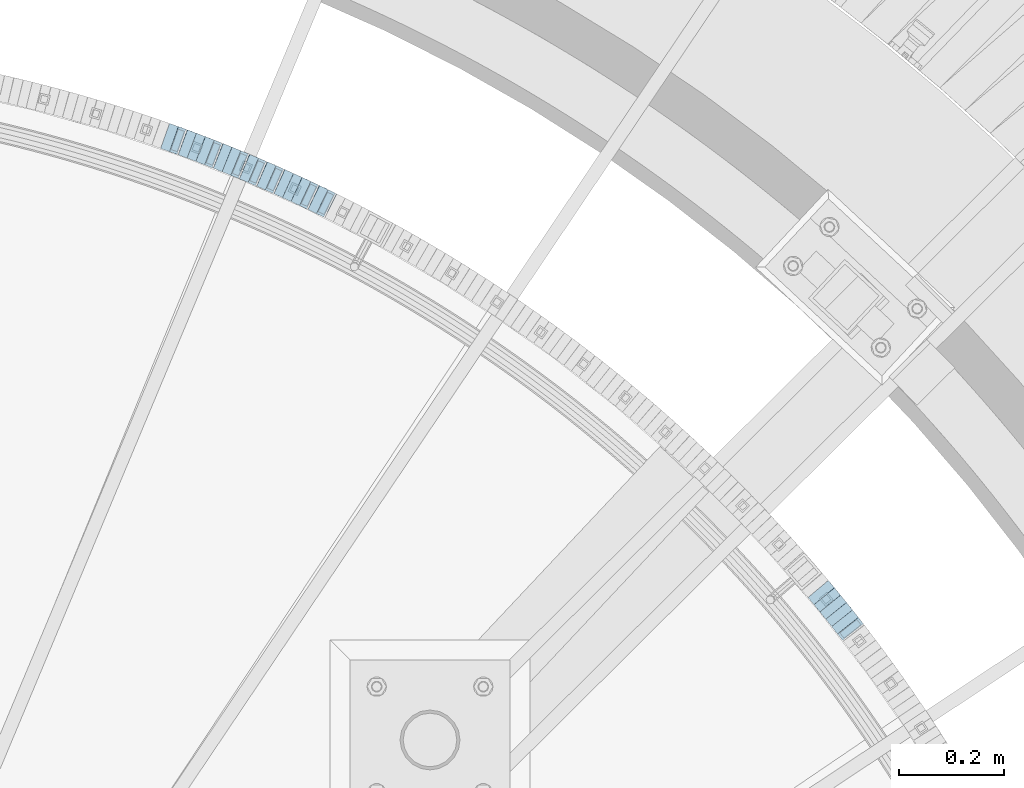
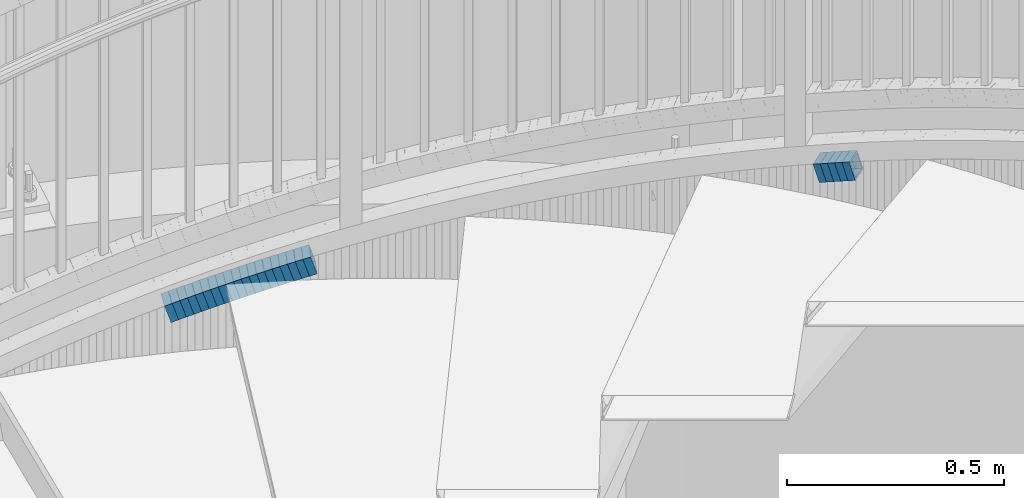
# One storey, part 811 of 975: 24 beams.
"""IFC2X3 building model written with IfcOpenShell, lengths in millimetres."""

from ifc_helpers import new_model, si_unit, frame, origin_with_axes, place, context, subcontext, project, spatial, faceted_brep, material, type_object, element, save


model = new_model("IFC2X3")

# Units and contexts
model_context = context("Model", 3, precision=1e-05, world=origin_with_axes())
body_context = subcontext(model_context, "Body", "Model", "MODEL_VIEW")
ifc_project = project(units=[si_unit("LENGTHUNIT", "METRE", prefix="MILLI"), si_unit("AREAUNIT", "SQUARE_METRE"), si_unit("VOLUMEUNIT", "CUBIC_METRE"), si_unit("MASSUNIT", "GRAM", prefix="KILO"), si_unit("TIMEUNIT", "SECOND"), si_unit("PLANEANGLEUNIT", "RADIAN"), si_unit("SOLIDANGLEUNIT", "STERADIAN"), si_unit("THERMODYNAMICTEMPERATUREUNIT", "DEGREE_CELSIUS"), si_unit("LUMINOUSINTENSITYUNIT", "LUMEN")], contexts=[model_context])

# Site, building, storey
site_placement = place(None, origin_with_axes())
site = spatial("IfcSite", under=ifc_project, at=site_placement, CompositionType="ELEMENT")
building_placement = place(site_placement, origin_with_axes())
building = spatial("IfcBuilding", under=site, at=building_placement, Name="Undefined", CompositionType="ELEMENT")
storey_placement = place(building_placement, origin_with_axes())
storey = spatial("IfcBuildingStorey", under=building, at=storey_placement, Name="Undefined", CompositionType="ELEMENT", Elevation=0.0)

# Beams
ifc_material = material()
beam_type = type_object("IfcBeamType", Name="HSS2X2X.188_TUBES", PredefinedType="NOTDEFINED")
beam_1_placement = place(storey_placement, frame((36997.0512859176, 5170.59248013591, 1868.54111427349), z_axis=(-0.783591636094263, -0.621276225074737, 0.0), x_axis=(-0.590918950773121, 0.745303180713798, -0.308768460881435)))
element("IfcBeam", 1, at=beam_1_placement, inside=storey, type_object=beam_type, material=ifc_material, Name="WALL", ObjectType="HSS2X2X.188_TUBES", context=body_context, shape_type="Brep", body=[
    faceted_brep([(0.0, 20.6374999999753, -20.6375000000298), (0.0, -20.6375000000153, -20.6375000000153), (18.7771137292038, -20.637500000008, -20.6374999999862), (18.777113729182, 20.6375000000062, -20.6375000000189), (0.0, -20.6374999999825, 20.6375000000335), (18.7771137291729, -20.6374999999916, 20.6374999999753), (0.0, 20.6375000000116, 20.6375000000189), (18.7771137291529, 20.6375000000207, 20.6374999999389), (0.0, 25.3999999999724, -25.4000000000342), (0.0, 25.400000000016, 25.4000000000196), (18.7771137291475, 25.4000000000251, 25.3999999999287), (18.7771137291857, 25.4000000000051, -25.4000000000196), (0.0, -25.399999999976, 25.4000000000378), (18.7771137291711, -25.3999999999905, 25.3999999999724), (0.0, -25.400000000016, -25.4000000000196), (18.7771137292129, -25.4000000000124, -25.3999999999724)], [[[0, 1, 2, 3]], [[1, 4, 5, 2]], [[4, 6, 7, 5]], [[6, 0, 3, 7]], [[8, 9, 10, 11]], [[9, 12, 13, 10]], [[12, 14, 15, 13]], [[14, 8, 11, 15]], [[13, 15, 11, 10], [5, 7, 3, 2]], [[14, 12, 9, 8], [6, 4, 1, 0]]]),
])
beam_2_placement = place(storey_placement, frame((36985.8171164362, 5184.81545076924, 1862.69389080845), z_axis=(-0.780868809052786, -0.624695048042229, 0.0), x_axis=(-0.595332147207223, 0.744165184258822, -0.30298153910539)))
element("IfcBeam", 2, at=beam_2_placement, inside=storey, type_object=beam_type, material=ifc_material, Name="WALL", ObjectType="HSS2X2X.188_TUBES", context=body_context, shape_type="Brep", body=[
    faceted_brep([(0.0, 20.6374999999753, -20.6375000000298), (0.0, -20.6375000000153, -20.6375000000153), (18.8066477608099, -20.6374999999862, -20.6375000000116), (18.8066477608172, 20.6375000000062, -20.6374999999971), (0.0, -20.6374999999825, 20.6375000000335), (18.8066477608463, -20.6375000000062, 20.6375000000407), (0.0, 20.6375000000116, 20.6375000000189), (18.8066477608536, 20.6374999999844, 20.637500000048), (0.0, 25.3999999999724, -25.4000000000342), (0.0, 25.400000000016, 25.4000000000196), (18.8066477608591, 25.3999999999814, 25.400000000056), (18.8066477608154, 25.4000000000051, -25.4000000000015), (0.0, -25.399999999976, 25.4000000000378), (18.8066477608518, -25.4000000000087, 25.4000000000451), (0.0, -25.400000000016, -25.4000000000196), (18.8066477608081, -25.3999999999851, -25.4000000000196)], [[[0, 1, 2, 3]], [[1, 4, 5, 2]], [[4, 6, 7, 5]], [[6, 0, 3, 7]], [[8, 9, 10, 11]], [[9, 12, 13, 10]], [[12, 14, 15, 13]], [[14, 8, 11, 15]], [[13, 15, 11, 10], [5, 7, 3, 2]], [[14, 12, 9, 8], [6, 4, 1, 0]]]),
])
beam_3_placement = place(storey_placement, frame((36974.5857562795, 5198.94093483441, 1857.01342313973), z_axis=(-0.776458094333385, -0.630168888270572, 0.0), x_axis=(-0.600064104965527, 0.73936469995768, -0.305389767982512)))
element("IfcBeam", 3, at=beam_3_placement, inside=storey, type_object=beam_type, material=ifc_material, Name="WALL", ObjectType="HSS2X2X.188_TUBES", context=body_context, shape_type="Brep", body=[
    faceted_brep([(0.0, 20.6374999999753, -20.6375000000298), (0.0, -20.6375000000153, -20.6375000000153), (18.6593140280638, -20.6374999999971, -20.6375000000226), (18.6593140281293, 20.6374999999862, -20.6374999999862), (0.0, -20.6374999999825, 20.6375000000335), (18.6593140281693, -20.6375000000226, 20.6375000000407), (0.0, 20.6375000000116, 20.6375000000189), (18.6593140282275, 20.6374999999625, 20.6375000000771), (0.0, 25.3999999999724, -25.4000000000342), (0.0, 25.400000000016, 25.4000000000196), (18.6593140282457, 25.3999999999578, 25.4000000000888), (18.6593140281184, 25.3999999999887, -25.3999999999905), (0.0, -25.399999999976, 25.4000000000378), (18.6593140281766, -25.4000000000233, 25.4000000000487), (0.0, -25.400000000016, -25.4000000000196), (18.6593140280456, -25.3999999999905, -25.4000000000342)], [[[0, 1, 2, 3]], [[1, 4, 5, 2]], [[4, 6, 7, 5]], [[6, 0, 3, 7]], [[8, 9, 10, 11]], [[9, 12, 13, 10]], [[12, 14, 15, 13]], [[14, 8, 11, 15]], [[13, 15, 11, 10], [5, 7, 3, 2]], [[14, 12, 9, 8], [6, 4, 1, 0]]]),
])
beam_4_placement = place(storey_placement, frame((36963.3262692101, 5212.86726272225, 1851.30544234421), z_axis=(-0.773707440821245, -0.633543049853631, 0.0), x_axis=(-0.603476136068645, 0.736988555083872, -0.304408316034639)))
element("IfcBeam", 4, at=beam_4_placement, inside=storey, type_object=beam_type, material=ifc_material, Name="WALL", ObjectType="HSS2X2X.188_TUBES", context=body_context, shape_type="Brep", body=[
    faceted_brep([(0.0, 20.6374999999753, -20.6375000000298), (0.0, -20.6375000000153, -20.6375000000153), (18.724849799155, -20.6375000000171, -20.6374999999425), (18.7248497991204, 20.6374999999989, -20.6375000000007), (0.0, -20.6374999999825, 20.6375000000335), (18.7248497991168, -20.6374999999953, 20.6375000000007), (0.0, 20.6375000000116, 20.6375000000189), (18.724849799084, 20.6375000000226, 20.6374999999498), (0.0, 25.3999999999724, -25.4000000000342), (0.0, 25.400000000016, 25.4000000000196), (18.7248497990731, 25.4000000000269, 25.399999999936), (18.7248497991204, 25.3999999999978, -25.3999999999978), (0.0, -25.399999999976, 25.4000000000378), (18.7248497991186, -25.3999999999942, 25.4000000000051), (0.0, -25.400000000016, -25.4000000000196), (18.7248497991604, -25.4000000000233, -25.3999999999323)], [[[0, 1, 2, 3]], [[1, 4, 5, 2]], [[4, 6, 7, 5]], [[6, 0, 3, 7]], [[8, 9, 10, 11]], [[9, 12, 13, 10]], [[12, 14, 15, 13]], [[14, 8, 11, 15]], [[13, 15, 11, 10], [5, 7, 3, 2]], [[14, 12, 9, 8], [6, 4, 1, 0]]]),
])
beam_5_placement = place(storey_placement, frame((36951.967170882, 5226.88723935818, 1845.63848619707), z_axis=(-0.765925091094034, -0.642929821078939, 0.0), x_axis=(-0.611581013932062, 0.728579120919108, -0.308449554965754)))
element("IfcBeam", 5, at=beam_5_placement, inside=storey, type_object=beam_type, material=ifc_material, Name="WALL", ObjectType="HSS2X2X.188_TUBES", context=body_context, shape_type="Brep", body=[
    faceted_brep([(0.0, 20.6374999999753, -20.6375000000298), (0.0, -20.6375000000153, -20.6375000000153), (18.8047866246379, -20.6374999999916, -20.6375000000298), (18.8047866247143, 20.6374999999844, -20.6374999999643), (0.0, -20.6374999999825, 20.6375000000335), (18.8047866247107, -20.6375000000189, 20.6375000000407), (0.0, 20.6375000000116, 20.6375000000189), (18.8047866247907, 20.6374999999589, 20.6375000001026), (0.0, 25.3999999999724, -25.4000000000342), (0.0, 25.400000000016, 25.4000000000196), (18.8047866248016, 25.3999999999542, 25.4000000001142), (18.8047866247143, 25.3999999999851, -25.3999999999651), (0.0, -25.399999999976, 25.4000000000378), (18.8047866247107, -25.4000000000196, 25.4000000000415), (0.0, -25.400000000016, -25.4000000000196), (18.8047866246197, -25.3999999999887, -25.4000000000378)], [[[0, 1, 2, 3]], [[1, 4, 5, 2]], [[4, 6, 7, 5]], [[6, 0, 3, 7]], [[8, 9, 10, 11]], [[9, 12, 13, 10]], [[12, 14, 15, 13]], [[14, 8, 11, 15]], [[13, 15, 11, 10], [5, 7, 3, 2]], [[14, 12, 9, 8], [6, 4, 1, 0]]]),
])
beam_6_placement = place(storey_placement, frame((36012.8688079103, 5973.99459632601, 1461.31000510045), z_axis=(-0.438202247231412, -0.898876404474686, 0.0), x_axis=(-0.856055734430965, 0.417327170210044, -0.304969855153487)))
element("IfcBeam", 6, at=beam_6_placement, inside=storey, type_object=beam_type, material=ifc_material, Name="WALL", ObjectType="HSS2X2X.188_TUBES", context=body_context, shape_type="Brep", body=[
    faceted_brep([(0.0, 20.6374999999753, -20.6375000000298), (0.0, -20.6375000000153, -20.6375000000153), (18.6895692834223, -20.637499999988, -20.6374999999862), (18.6895692834369, 20.6374999999953, -20.6374999999534), (0.0, -20.6374999999825, 20.6375000000335), (18.6895692833914, -20.637499999988, 20.6374999999789), (0.0, 20.6375000000116, 20.6375000000189), (18.6895692834078, 20.6374999999953, 20.637500000008), (0.0, 25.3999999999724, -25.4000000000342), (0.0, 25.400000000016, 25.4000000000196), (18.6895692834059, 25.3999999999924, 25.4000000000087), (18.6895692834423, 25.3999999999942, -25.3999999999432), (0.0, -25.399999999976, 25.4000000000378), (18.6895692833878, -25.3999999999869, 25.3999999999687), (0.0, -25.400000000016, -25.4000000000196), (18.6895692834241, -25.3999999999869, -25.3999999999833)], [[[0, 1, 2, 3]], [[1, 4, 5, 2]], [[4, 6, 7, 5]], [[6, 0, 3, 7]], [[8, 9, 10, 11]], [[9, 12, 13, 10]], [[12, 14, 15, 13]], [[14, 8, 11, 15]], [[13, 15, 11, 10], [5, 7, 3, 2]], [[14, 12, 9, 8], [6, 4, 1, 0]]]),
])
beam_7_placement = place(storey_placement, frame((35996.7893336974, 5981.85426736592, 1455.59871466266), z_axis=(-0.435999194636046, -0.899947055263096, 1.4090551303525e-10), x_axis=(-0.857475412684092, 0.415422870847002, -0.303578251888178)))
element("IfcBeam", 7, at=beam_7_placement, inside=storey, type_object=beam_type, material=ifc_material, Name="WALL", ObjectType="HSS2X2X.188_TUBES", context=body_context, shape_type="Brep", body=[
    faceted_brep([(0.0, 20.6374999999753, -20.6375000000298), (0.0, -20.6375000000153, -20.6375000000153), (18.7771137292038, -20.637500000008, -20.6374999999862), (18.777113729182, 20.6375000000062, -20.6375000000189), (0.0, -20.6374999999825, 20.6375000000335), (18.7771137291729, -20.6374999999916, 20.6374999999753), (0.0, 20.6375000000116, 20.6375000000189), (18.7771137291529, 20.6375000000207, 20.6374999999389), (0.0, 25.3999999999724, -25.4000000000342), (0.0, 25.400000000016, 25.4000000000196), (18.7771137291475, 25.4000000000251, 25.3999999999287), (18.7771137291857, 25.4000000000051, -25.4000000000196), (0.0, -25.399999999976, 25.4000000000378), (18.7771137291711, -25.3999999999905, 25.3999999999724), (0.0, -25.400000000016, -25.4000000000196), (18.7771137292129, -25.4000000000124, -25.3999999999724)], [[[0, 1, 2, 3]], [[1, 4, 5, 2]], [[4, 6, 7, 5]], [[6, 0, 3, 7]], [[8, 9, 10, 11]], [[9, 12, 13, 10]], [[12, 14, 15, 13]], [[14, 8, 11, 15]], [[13, 15, 11, 10], [5, 7, 3, 2]], [[14, 12, 9, 8], [6, 4, 1, 0]]]),
])
beam_8_placement = place(storey_placement, frame((35980.5537240716, 5989.82650117353, 1449.93755285458), z_axis=(-0.424720211576408, -0.905324661035195, 3.22928826790303e-10), x_axis=(-0.861214932569691, 0.404026758267331, -0.308336210204014)))
element("IfcBeam", 8, at=beam_8_placement, inside=storey, type_object=beam_type, material=ifc_material, Name="WALL", ObjectType="HSS2X2X.188_TUBES", context=body_context, shape_type="Brep", body=[
    faceted_brep([(0.0, 20.6374999999753, -20.6375000000298), (0.0, -20.6375000000153, -20.6375000000153), (18.8066477608099, -20.6374999999862, -20.6375000000116), (18.8066477608172, 20.6375000000062, -20.6374999999971), (0.0, -20.6374999999825, 20.6375000000335), (18.8066477608463, -20.6375000000062, 20.6375000000407), (0.0, 20.6375000000116, 20.6375000000189), (18.8066477608536, 20.6374999999844, 20.637500000048), (0.0, 25.3999999999724, -25.4000000000342), (0.0, 25.400000000016, 25.4000000000196), (18.8066477608591, 25.3999999999814, 25.400000000056), (18.8066477608154, 25.4000000000051, -25.4000000000015), (0.0, -25.399999999976, 25.4000000000378), (18.8066477608518, -25.4000000000087, 25.4000000000451), (0.0, -25.400000000016, -25.4000000000196), (18.8066477608081, -25.3999999999851, -25.4000000000196)], [[[0, 1, 2, 3]], [[1, 4, 5, 2]], [[4, 6, 7, 5]], [[6, 0, 3, 7]], [[8, 9, 10, 11]], [[9, 12, 13, 10]], [[12, 14, 15, 13]], [[14, 8, 11, 15]], [[13, 15, 11, 10], [5, 7, 3, 2]], [[14, 12, 9, 8], [6, 4, 1, 0]]]),
])
beam_9_placement = place(storey_placement, frame((35964.2428289937, 5997.47852602488, 1444.09819222583), z_axis=(-0.424720211576408, -0.905324661035195, 3.22928826790303e-10), x_axis=(-0.862617851630771, 0.404684917826714, -0.303513688870039)))
element("IfcBeam", 9, at=beam_9_placement, inside=storey, type_object=beam_type, material=ifc_material, Name="WALL", ObjectType="HSS2X2X.188_TUBES", context=body_context, shape_type="Brep", body=[
    faceted_brep([(0.0, 20.6374999999753, -20.6375000000298), (0.0, -20.6375000000153, -20.6375000000153), (18.7771137292038, -20.637500000008, -20.6374999999862), (18.777113729182, 20.6375000000062, -20.6375000000189), (0.0, -20.6374999999825, 20.6375000000335), (18.7771137291729, -20.6374999999916, 20.6374999999753), (0.0, 20.6375000000116, 20.6375000000189), (18.7771137291529, 20.6375000000207, 20.6374999999389), (0.0, 25.3999999999724, -25.4000000000342), (0.0, 25.400000000016, 25.4000000000196), (18.7771137291475, 25.4000000000251, 25.3999999999287), (18.7771137291857, 25.4000000000051, -25.4000000000196), (0.0, -25.399999999976, 25.4000000000378), (18.7771137291711, -25.3999999999905, 25.3999999999724), (0.0, -25.400000000016, -25.4000000000196), (18.7771137292129, -25.4000000000124, -25.3999999999724)], [[[0, 1, 2, 3]], [[1, 4, 5, 2]], [[4, 6, 7, 5]], [[6, 0, 3, 7]], [[8, 9, 10, 11]], [[9, 12, 13, 10]], [[12, 14, 15, 13]], [[14, 8, 11, 15]], [[13, 15, 11, 10], [5, 7, 3, 2]], [[14, 12, 9, 8], [6, 4, 1, 0]]]),
])
beam_10_placement = place(storey_placement, frame((35947.8714343465, 6005.24442561261, 1438.40872829904), z_axis=(-0.415494357820709, -0.909595755607488, 0.0), x_axis=(-0.86631016042621, 0.395721925194681, -0.304812834149958)))
element("IfcBeam", 10, at=beam_10_placement, inside=storey, type_object=beam_type, material=ifc_material, Name="WALL", ObjectType="HSS2X2X.188_TUBES", context=body_context, shape_type="Brep", body=[
    faceted_brep([(0.0, 20.6374999999753, -20.6375000000298), (0.0, -20.6375000000153, -20.6375000000153), (18.6959888745805, -20.6374999999771, -20.6375000000407), (18.6959888746751, 20.637499999988, -20.6374999999716), (0.0, -20.6374999999825, 20.6375000000335), (18.6959888746969, -20.6375000000135, 20.6375000000371), (0.0, 20.6375000000116, 20.6375000000189), (18.6959888747988, 20.6374999999498, 20.6375000001062), (0.0, 25.3999999999724, -25.4000000000342), (0.0, 25.400000000016, 25.4000000000196), (18.695988874817, 25.3999999999414, 25.4000000001215), (18.6959888746678, 25.3999999999887, -25.399999999976), (0.0, -25.399999999976, 25.4000000000378), (18.6959888747042, -25.4000000000124, 25.4000000000378), (0.0, -25.400000000016, -25.4000000000196), (18.695988874555, -25.3999999999687, -25.4000000000597)], [[[0, 1, 2, 3]], [[1, 4, 5, 2]], [[4, 6, 7, 5]], [[6, 0, 3, 7]], [[8, 9, 10, 11]], [[9, 12, 13, 10]], [[12, 14, 15, 13]], [[14, 8, 11, 15]], [[13, 15, 11, 10], [5, 7, 3, 2]], [[14, 12, 9, 8], [6, 4, 1, 0]]]),
])
beam_11_placement = place(storey_placement, frame((35931.7041997955, 6012.64936097456, 1432.73665673924), z_axis=(-0.41338201913335, -0.910557689692001, -8.05939635029062e-11), x_axis=(-0.866225119080324, 0.393255576036498, -0.308227343028617)))
element("IfcBeam", 11, at=beam_11_placement, inside=storey, type_object=beam_type, material=ifc_material, Name="WALL", ObjectType="HSS2X2X.188_TUBES", context=body_context, shape_type="Brep", body=[
    faceted_brep([(0.0, 20.6374999999753, -20.6375000000298), (0.0, -20.6375000000153, -20.6375000000153), (18.8225928075335, -20.6374999999935, -20.6375000000298), (18.8225928075699, 20.6374999999898, -20.6374999999825), (0.0, -20.6374999999825, 20.6375000000335), (18.8225928075772, -20.637500000008, 20.6375000000226), (0.0, 20.6375000000116, 20.6375000000189), (18.8225928076135, 20.6374999999753, 20.6375000000698), (0.0, 25.3999999999724, -25.4000000000342), (0.0, 25.400000000016, 25.4000000000196), (18.8225928076281, 25.3999999999705, 25.4000000000815), (18.8225928075663, 25.3999999999905, -25.3999999999796), (0.0, -25.399999999976, 25.4000000000378), (18.8225928075808, -25.4000000000087, 25.4000000000233), (0.0, -25.400000000016, -25.4000000000196), (18.8225928075226, -25.3999999999905, -25.4000000000378)], [[[0, 1, 2, 3]], [[1, 4, 5, 2]], [[4, 6, 7, 5]], [[6, 0, 3, 7]], [[8, 9, 10, 11]], [[9, 12, 13, 10]], [[12, 14, 15, 13]], [[14, 8, 11, 15]], [[13, 15, 11, 10], [5, 7, 3, 2]], [[14, 12, 9, 8], [6, 4, 1, 0]]]),
])
beam_12_placement = place(storey_placement, frame((35898.7511246729, 6027.46929561375, 1421.23540435723), z_axis=(-0.401990062304751, -0.915644030072944, 1.61733169079525e-10), x_axis=(-0.871108966777094, 0.382438082902087, -0.308075121921133)))
element("IfcBeam", 12, at=beam_12_placement, inside=storey, type_object=beam_type, material=ifc_material, Name="WALL", ObjectType="HSS2X2X.188_TUBES", context=body_context, shape_type="Brep", body=[
    faceted_brep([(0.0, 20.6374999999753, -20.6375000000298), (0.0, -20.6375000000153, -20.6375000000153), (18.8332159191086, -20.6374999999916, -20.6375000000153), (18.8332159190923, 20.6375000000062, -20.6375000000335), (0.0, -20.6374999999825, 20.6375000000335), (18.8332159191377, -20.6375000000062, 20.6375000000335), (0.0, 20.6375000000116, 20.6375000000189), (18.8332159191141, 20.6374999999916, 20.6375000000116), (0.0, 25.3999999999724, -25.4000000000342), (0.0, 25.400000000016, 25.4000000000196), (18.8332159191159, 25.3999999999905, 25.4000000000124), (18.8332159190886, 25.4000000000069, -25.4000000000415), (0.0, -25.399999999976, 25.4000000000378), (18.8332159191395, -25.4000000000069, 25.4000000000378), (0.0, -25.400000000016, -25.4000000000196), (18.8332159191104, -25.3999999999905, -25.400000000016)], [[[0, 1, 2, 3]], [[1, 4, 5, 2]], [[4, 6, 7, 5]], [[6, 0, 3, 7]], [[8, 9, 10, 11]], [[9, 12, 13, 10]], [[12, 14, 15, 13]], [[14, 8, 11, 15]], [[13, 15, 11, 10], [5, 7, 3, 2]], [[14, 12, 9, 8], [6, 4, 1, 0]]]),
])
beam_13_placement = place(storey_placement, frame((35915.0390410617, 6020.31850305279, 1426.89610702731), z_axis=(-0.401990062304751, -0.915644030072944, 1.61733169079525e-10), x_axis=(-0.872525595308094, 0.38306001713522, -0.303255847107061)))
element("IfcBeam", 13, at=beam_13_placement, inside=storey, type_object=beam_type, material=ifc_material, Name="WALL", ObjectType="HSS2X2X.188_TUBES", context=body_context, shape_type="Brep", body=[
    faceted_brep([(0.0, 20.6374999999753, -20.6375000000298), (0.0, -20.6375000000153, -20.6375000000153), (18.8047866246379, -20.6374999999916, -20.6375000000298), (18.8047866247143, 20.6374999999844, -20.6374999999643), (0.0, -20.6374999999825, 20.6375000000335), (18.8047866247107, -20.6375000000189, 20.6375000000407), (0.0, 20.6375000000116, 20.6375000000189), (18.8047866247907, 20.6374999999589, 20.6375000001026), (0.0, 25.3999999999724, -25.4000000000342), (0.0, 25.400000000016, 25.4000000000196), (18.8047866248016, 25.3999999999542, 25.4000000001142), (18.8047866247143, 25.3999999999851, -25.3999999999651), (0.0, -25.399999999976, 25.4000000000378), (18.8047866247107, -25.4000000000196, 25.4000000000415), (0.0, -25.400000000016, -25.4000000000196), (18.8047866246197, -25.3999999999887, -25.4000000000378)], [[[0, 1, 2, 3]], [[1, 4, 5, 2]], [[4, 6, 7, 5]], [[6, 0, 3, 7]], [[8, 9, 10, 11]], [[9, 12, 13, 10]], [[12, 14, 15, 13]], [[14, 8, 11, 15]], [[13, 15, 11, 10], [5, 7, 3, 2]], [[14, 12, 9, 8], [6, 4, 1, 0]]]),
])
for number, where, z_axis, x_axis, name in (
    (14, (35865.4819818922, 6041.93395653561, 1409.69454788788), (-0.39054984693668, -0.920581781841101, -1.19734977488406e-12), (-0.877287332469951, 0.372182504775149, -0.303062896816905), "WALL"),
    (15, (35881.9819818922, 6034.93395653562, 1415.3945478879), (-0.39054984693668, -0.920581781841101, -1.19734977488406e-12), (-0.877287332469951, 0.372182504775149, -0.303062896816905), "WALL"),
):
    element("IfcBeam", number, at=place(storey_placement, frame(where, z_axis=z_axis, x_axis=x_axis)), inside=storey, type_object=beam_type, material=ifc_material, Name=name, ObjectType="HSS2X2X.188_TUBES", context=body_context, shape_type="Brep", body=[
        faceted_brep([(0.0, 20.6374999999753, -20.6375000000298), (0.0, -20.6375000000153, -20.6375000000153), (18.8066477608099, -20.6374999999862, -20.6375000000116), (18.8066477608172, 20.6375000000062, -20.6374999999971), (0.0, -20.6374999999825, 20.6375000000335), (18.8066477608463, -20.6375000000062, 20.6375000000407), (0.0, 20.6375000000116, 20.6375000000189), (18.8066477608536, 20.6374999999844, 20.637500000048), (0.0, 25.3999999999724, -25.4000000000342), (0.0, 25.400000000016, 25.4000000000196), (18.8066477608591, 25.3999999999814, 25.400000000056), (18.8066477608154, 25.4000000000051, -25.4000000000015), (0.0, -25.399999999976, 25.4000000000378), (18.8066477608518, -25.4000000000087, 25.4000000000451), (0.0, -25.400000000016, -25.4000000000196), (18.8066477608081, -25.3999999999851, -25.4000000000196)], [[[0, 1, 2, 3]], [[1, 4, 5, 2]], [[4, 6, 7, 5]], [[6, 0, 3, 7]], [[8, 9, 10, 11]], [[9, 12, 13, 10]], [[12, 14, 15, 13]], [[14, 8, 11, 15]], [[13, 15, 11, 10], [5, 7, 3, 2]], [[14, 12, 9, 8], [6, 4, 1, 0]]]),
    ])
for number, where, z_axis, x_axis, name in (
    (16, (35832.2347846711, 6055.89986802363, 1398.23184006875), (-0.379066925164675, -0.925369259401996, 0.0), (-0.880491033946545, 0.360683073978086, -0.307641445981296), "WALL"),
    (17, (35848.8347838429, 6049.09986854204, 1404.03183993165), (-0.379066925164675, -0.925369259401996, 0.0), (-0.880491033946545, 0.360683073978086, -0.307641445981296), "WALL"),
):
    element("IfcBeam", number, at=place(storey_placement, frame(where, z_axis=z_axis, x_axis=x_axis)), inside=storey, type_object=beam_type, material=ifc_material, Name=name, ObjectType="HSS2X2X.188_TUBES", context=body_context, shape_type="Brep", body=[
        faceted_brep([(0.0, 20.6374999999753, -20.6375000000298), (0.0, -20.6375000000153, -20.6375000000153), (18.8480768248774, -20.6374999999716, -20.6375000000735), (18.8480768249356, 20.6375000000153, -20.6375000000226), (0.0, -20.6374999999825, 20.6375000000335), (18.8480768249283, -20.6374999999935, 20.6374999999716), (0.0, 20.6375000000116, 20.6375000000189), (18.8480768249865, 20.6374999999935, 20.6375000000262), (0.0, 25.3999999999724, -25.4000000000342), (0.0, 25.400000000016, 25.4000000000196), (18.848076825001, 25.3999999999887, 25.4000000000378), (18.8480768249392, 25.4000000000142, -25.4000000000233), (0.0, -25.399999999976, 25.4000000000378), (18.8480768249283, -25.399999999996, 25.3999999999833), (0.0, -25.400000000016, -25.4000000000196), (18.8480768248664, -25.3999999999687, -25.4000000000779)], [[[0, 1, 2, 3]], [[1, 4, 5, 2]], [[4, 6, 7, 5]], [[6, 0, 3, 7]], [[8, 9, 10, 11]], [[9, 12, 13, 10]], [[12, 14, 15, 13]], [[14, 8, 11, 15]], [[13, 15, 11, 10], [5, 7, 3, 2]], [[14, 12, 9, 8], [6, 4, 1, 0]]]),
    ])
beam_14_placement = place(storey_placement, frame((35815.4286123621, 6062.82700788712, 1392.39732250949), z_axis=(-0.374278314232667, -0.927316420373948, -2.41343514062465e-11), x_axis=(-0.883603947282875, 0.356635328114137, -0.303406175097088)))
element("IfcBeam", 18, at=beam_14_placement, inside=storey, type_object=beam_type, material=ifc_material, Name="WALL", ObjectType="HSS2X2X.188_TUBES", context=body_context, shape_type="Brep", body=[
    faceted_brep([(0.0, 20.6374999999753, -20.6375000000298), (0.0, -20.6375000000153, -20.6375000000153), (18.7853666454903, -20.6375000000535, -20.6375000000326), (18.785366645363, 20.6374999999862, -20.6375000000044), (0.0, -20.6374999999825, 20.6375000000335), (18.785366645352, -20.6375000000007, 20.6374999999989), (0.0, 20.6375000000116, 20.6375000000189), (18.7853666453102, 20.6375000000025, 20.6374999999753), (0.0, 25.3999999999724, -25.4000000000342), (0.0, 25.400000000016, 25.4000000000196), (18.7853666452065, 25.4000000000451, 25.4000000000351), (18.7853666453739, 25.3999999999833, -25.400000000006), (0.0, -25.399999999976, 25.4000000000378), (18.7853666497213, -25.399999993424, 25.3999999995158), (0.0, -25.400000000016, -25.4000000000196), (18.7853666455194, -25.4000000000633, -25.4000000000406)], [[[0, 1, 2, 3]], [[1, 4, 5, 2]], [[4, 6, 7, 5]], [[6, 0, 3, 7]], [[8, 9, 10, 11]], [[9, 12, 13, 10]], [[12, 14, 15, 13]], [[14, 8, 11, 15]], [[13, 15, 11, 10], [5, 7, 3, 2]], [[14, 12, 9, 8], [6, 4, 1, 0]]]),
])
beam_15_placement = place(storey_placement, frame((35781.9772606165, 6076.19088273127, 1381.03419018556), z_axis=(-0.362715533424729, -0.931899909760922, 1.45443891597097e-10), x_axis=(-0.886618739868716, 0.345091125948879, -0.307927466954387)))
element("IfcBeam", 19, at=beam_15_placement, inside=storey, type_object=beam_type, material=ifc_material, Name="WALL", ObjectType="HSS2X2X.188_TUBES", context=body_context, shape_type="Brep", body=[
    faceted_brep([(0.0, 20.6374999999753, -20.6375000000298), (0.0, -20.6375000000153, -20.6375000000153), (18.8433011969464, -20.6374999999898, -20.6375000000226), (18.8433011969719, 20.6375000000007, -20.6374999999862), (0.0, -20.6374999999825, 20.6375000000335), (18.8433011969828, -20.6375000000044, 20.6375000000189), (0.0, 20.6375000000116, 20.6375000000189), (18.8433011970155, 20.6374999999862, 20.6375000000517), (0.0, 25.3999999999724, -25.4000000000342), (0.0, 25.400000000016, 25.4000000000196), (18.8433011970228, 25.3999999999833, 25.4000000000597), (18.8433011969719, 25.4000000000015, -25.3999999999869), (0.0, -25.399999999976, 25.4000000000378), (18.8433011969864, -25.4000000000051, 25.4000000000196), (0.0, -25.400000000016, -25.4000000000196), (18.8433011969391, -25.3999999999869, -25.4000000000269)], [[[0, 1, 2, 3]], [[1, 4, 5, 2]], [[4, 6, 7, 5]], [[6, 0, 3, 7]], [[8, 9, 10, 11]], [[9, 12, 13, 10]], [[12, 14, 15, 13]], [[14, 8, 11, 15]], [[13, 15, 11, 10], [5, 7, 3, 2]], [[14, 12, 9, 8], [6, 4, 1, 0]]]),
])
beam_16_placement = place(storey_placement, frame((35798.5632306127, 6069.73526566693, 1386.69492863504), z_axis=(-0.362715533424729, -0.931899909760922, 1.45443891597097e-10), x_axis=(-0.888059205870452, 0.345651786949542, -0.303110027955742)))
element("IfcBeam", 20, at=beam_16_placement, inside=storey, type_object=beam_type, material=ifc_material, Name="WALL", ObjectType="HSS2X2X.188_TUBES", context=body_context, shape_type="Brep", body=[
    faceted_brep([(0.0, 20.6374999999753, -20.6375000000298), (0.0, -20.6375000000153, -20.6375000000153), (18.8066477608099, -20.6374999999862, -20.6375000000116), (18.8066477608172, 20.6375000000062, -20.6374999999971), (0.0, -20.6374999999825, 20.6375000000335), (18.8066477608463, -20.6375000000062, 20.6375000000407), (0.0, 20.6375000000116, 20.6375000000189), (18.8066477608536, 20.6374999999844, 20.637500000048), (0.0, 25.3999999999724, -25.4000000000342), (0.0, 25.400000000016, 25.4000000000196), (18.8066477608591, 25.3999999999814, 25.400000000056), (18.8066477608154, 25.4000000000051, -25.4000000000015), (0.0, -25.399999999976, 25.4000000000378), (18.8066477608518, -25.4000000000087, 25.4000000000451), (0.0, -25.400000000016, -25.4000000000196), (18.8066477608081, -25.3999999999851, -25.4000000000196)], [[[0, 1, 2, 3]], [[1, 4, 5, 2]], [[4, 6, 7, 5]], [[6, 0, 3, 7]], [[8, 9, 10, 11]], [[9, 12, 13, 10]], [[12, 14, 15, 13]], [[14, 8, 11, 15]], [[13, 15, 11, 10], [5, 7, 3, 2]], [[14, 12, 9, 8], [6, 4, 1, 0]]]),
])
beam_17_placement = place(storey_placement, frame((35764.9705449852, 6082.89536000624, 1375.20385877047), z_axis=(-0.352964717885734, -0.935636632420858, -3.1137460609898e-11), x_axis=(-0.891291185330962, 0.336235597124792, -0.304213159112922)))
element("IfcBeam", 21, at=beam_17_placement, inside=storey, type_object=beam_type, material=ifc_material, Name="WALL", ObjectType="HSS2X2X.188_TUBES", context=body_context, shape_type="Brep", body=[
    faceted_brep([(0.0, 20.6374999999753, -20.6375000000298), (0.0, -20.6375000000153, -20.6375000000153), (18.7416648140024, -20.6375000000153, -20.6374999999825), (18.7416648139188, 20.6375000000189, -20.6375000000298), (0.0, -20.6374999999825, 20.6375000000335), (18.7416648140097, -20.6375000000189, 20.6375000000226), (0.0, 20.6375000000116, 20.6375000000189), (18.741664813926, 20.6375000000153, 20.6374999999753), (0.0, 25.3999999999724, -25.4000000000342), (0.0, 25.400000000016, 25.4000000000196), (18.7416648139224, 25.4000000000196, 25.3999999999687), (18.7416648139042, 25.4000000000233, -25.4000000000378), (0.0, -25.399999999976, 25.4000000000378), (18.7416648140133, -25.4000000000215, 25.4000000000269), (0.0, -25.400000000016, -25.4000000000196), (18.7416648140133, -25.4000000000196, -25.399999999976)], [[[0, 1, 2, 3]], [[1, 4, 5, 2]], [[4, 6, 7, 5]], [[6, 0, 3, 7]], [[8, 9, 10, 11]], [[9, 12, 13, 10]], [[12, 14, 15, 13]], [[14, 8, 11, 15]], [[13, 15, 11, 10], [5, 7, 3, 2]], [[14, 12, 9, 8], [6, 4, 1, 0]]]),
])
beam_18_placement = place(storey_placement, frame((35748.3093243709, 6089.19710453259, 1369.53137822217), z_axis=(-0.351123442136333, -0.936329177363566, 0.0), x_axis=(-0.890936447204326, 0.334101168076628, -0.307585202070526)))
element("IfcBeam", 22, at=beam_18_placement, inside=storey, type_object=beam_type, material=ifc_material, Name="WALL", ObjectType="HSS2X2X.188_TUBES", context=body_context, shape_type="Brep", body=[
    faceted_brep([(0.0, 20.6374999999753, -20.6375000000298), (0.0, -20.6375000000153, -20.6375000000153), (18.8565638439322, -20.6375000000116, -20.6374999999643), (18.8565638439395, 20.637499999988, -20.6374999999534), (0.0, -20.6374999999825, 20.6375000000335), (18.856563843914, -20.6374999999953, 20.6375000000116), (0.0, 20.6375000000116, 20.6375000000189), (18.8565638439177, 20.6375000000007, 20.6375000000226), (0.0, 25.3999999999724, -25.4000000000342), (0.0, 25.400000000016, 25.4000000000196), (18.8565638439177, 25.4000000000033, 25.4000000000233), (18.8565638439468, 25.3999999999851, -25.3999999999505), (0.0, -25.399999999976, 25.4000000000378), (18.8565638439104, -25.399999999996, 25.4000000000087), (0.0, -25.400000000016, -25.4000000000196), (18.8565638439395, -25.4000000000124, -25.3999999999614)], [[[0, 1, 2, 3]], [[1, 4, 5, 2]], [[4, 6, 7, 5]], [[6, 0, 3, 7]], [[8, 9, 10, 11]], [[9, 12, 13, 10]], [[12, 14, 15, 13]], [[14, 8, 11, 15]], [[13, 15, 11, 10], [5, 7, 3, 2]], [[14, 12, 9, 8], [6, 4, 1, 0]]]),
])
beam_19_placement = place(storey_placement, frame((35731.1985017513, 6095.69853203826, 1363.70080897596), z_axis=(-0.341293791922944, -0.93995667325407, 5.07523054693592e-11), x_axis=(-0.895519334726746, 0.325158805900798, -0.303836916907301)))
element("IfcBeam", 23, at=beam_19_placement, inside=storey, type_object=beam_type, material=ifc_material, Name="WALL", ObjectType="HSS2X2X.188_TUBES", context=body_context, shape_type="Brep", body=[
    faceted_brep([(0.0, 20.6374999999753, -20.6375000000298), (0.0, -20.6375000000153, -20.6375000000153), (18.7555325170906, -20.6374999999916, -20.6374999999971), (18.7555325171452, 20.637499999988, -20.6374999999571), (0.0, -20.6374999999825, 20.6375000000335), (18.7555325170615, -20.6374999999844, 20.6374999999716), (0.0, 20.6375000000116, 20.6375000000189), (18.7555325171015, 20.6374999999953, 20.637500000008), (0.0, 25.3999999999724, -25.4000000000342), (0.0, 25.400000000016, 25.4000000000196), (18.7555325171015, 25.399999999996, 25.4000000000051), (18.7555325171488, 25.3999999999851, -25.3999999999505), (0.0, -25.399999999976, 25.4000000000378), (18.755532517047, -25.3999999999814, 25.3999999999578), (0.0, -25.400000000016, -25.4000000000196), (18.7555325170979, -25.3999999999924, -25.3999999999978)], [[[0, 1, 2, 3]], [[1, 4, 5, 2]], [[4, 6, 7, 5]], [[6, 0, 3, 7]], [[8, 9, 10, 11]], [[9, 12, 13, 10]], [[12, 14, 15, 13]], [[14, 8, 11, 15]], [[13, 15, 11, 10], [5, 7, 3, 2]], [[14, 12, 9, 8], [6, 4, 1, 0]]]),
])
beam_20_placement = place(storey_placement, frame((35714.2241245026, 6101.9196378751, 1357.99330350148), z_axis=(-0.33456960089993, -0.942371042718133, 0.0), x_axis=(-0.898098024828027, 0.318851369938893, -0.302908800941946)))
element("IfcBeam", 24, at=beam_20_placement, inside=storey, type_object=beam_type, material=ifc_material, Name="WALL", ObjectType="HSS2X2X.188_TUBES", context=body_context, shape_type="Brep", body=[
    faceted_brep([(0.0, 20.6374999999753, -20.6375000000298), (0.0, -20.6375000000153, -20.6375000000153), (18.8225928075335, -20.6374999999935, -20.6375000000298), (18.8225928075699, 20.6374999999898, -20.6374999999825), (0.0, -20.6374999999825, 20.6375000000335), (18.8225928075772, -20.637500000008, 20.6375000000226), (0.0, 20.6375000000116, 20.6375000000189), (18.8225928076135, 20.6374999999753, 20.6375000000698), (0.0, 25.3999999999724, -25.4000000000342), (0.0, 25.400000000016, 25.4000000000196), (18.8225928076281, 25.3999999999705, 25.4000000000815), (18.8225928075663, 25.3999999999905, -25.3999999999796), (0.0, -25.399999999976, 25.4000000000378), (18.8225928075808, -25.4000000000087, 25.4000000000233), (0.0, -25.400000000016, -25.4000000000196), (18.8225928075226, -25.3999999999905, -25.4000000000378)], [[[0, 1, 2, 3]], [[1, 4, 5, 2]], [[4, 6, 7, 5]], [[6, 0, 3, 7]], [[8, 9, 10, 11]], [[9, 12, 13, 10]], [[12, 14, 15, 13]], [[14, 8, 11, 15]], [[13, 15, 11, 10], [5, 7, 3, 2]], [[14, 12, 9, 8], [6, 4, 1, 0]]]),
])

save(model, "model.ifc")
